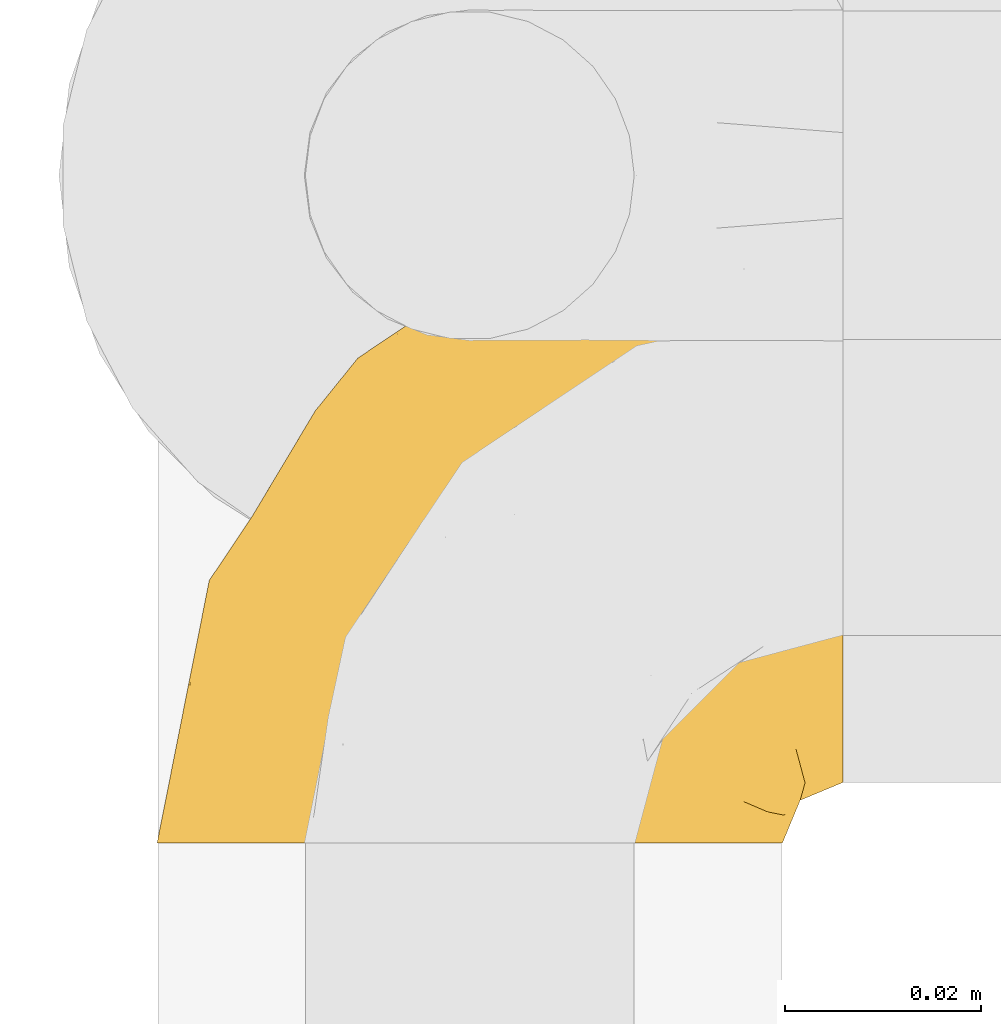
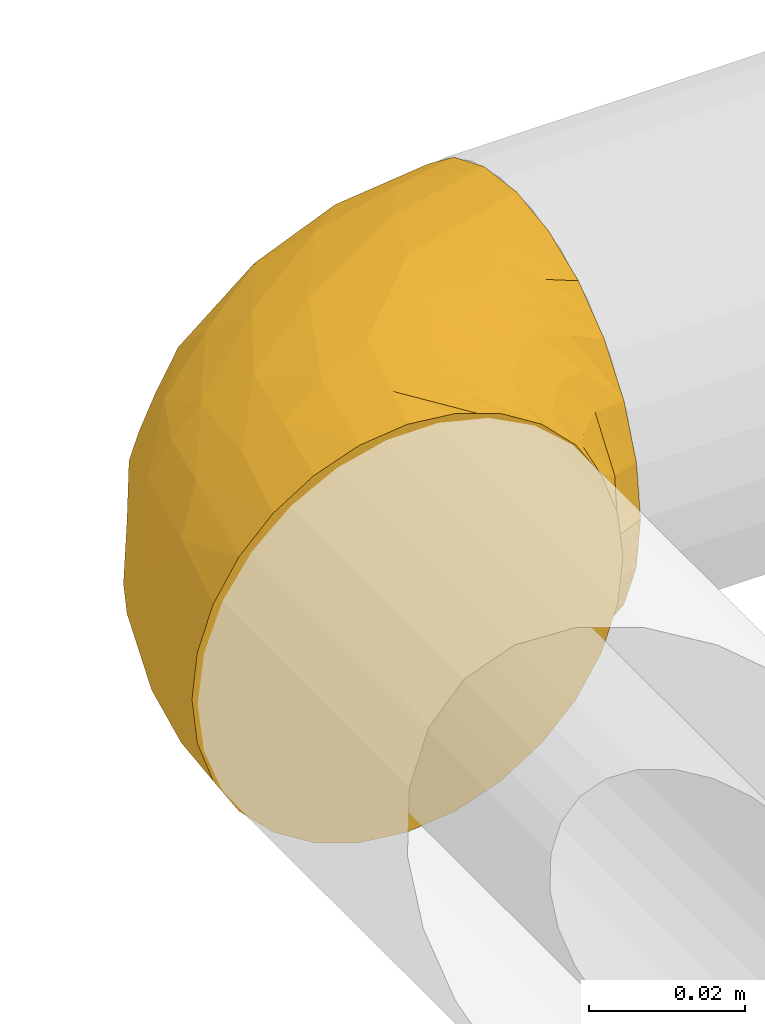
# One storey, part 26 of 39: 1 covering.
"""IFC2X3 building model written with IfcOpenShell, lengths in millimetres."""

from ifc_helpers import new_model, entity, si_unit, converted_unit, derived_unit, direction, frame, origin, place, context, subcontext, project, spatial, faceted_brep, element, save


model = new_model("IFC2X3")

# Units and contexts
model_context = context("Model", 3, precision=0.01, world=origin(), true_north=direction((6.12303176911189e-17, 1.0)))
body_context = subcontext(model_context, "Body", "Model", "MODEL_VIEW")
ifc_project = project(units=[si_unit("LENGTHUNIT", "METRE", prefix="MILLI"), si_unit("AREAUNIT", "SQUARE_METRE"), si_unit("VOLUMEUNIT", "CUBIC_METRE"), converted_unit("PLANEANGLEUNIT", "DEGREE", entity("IfcRatioMeasure", 0.0174532925199433), si_unit("PLANEANGLEUNIT", "RADIAN"), dimensions=[0, 0, 0, 0, 0, 0, 0]), si_unit("MASSUNIT", "GRAM", prefix="KILO"), derived_unit("MASSDENSITYUNIT", [(si_unit("MASSUNIT", "GRAM", prefix="KILO"), 1), (si_unit("LENGTHUNIT", "METRE"), -3)]), derived_unit("MOMENTOFINERTIAUNIT", [(si_unit("LENGTHUNIT", "METRE"), 4)]), si_unit("TIMEUNIT", "SECOND"), si_unit("FREQUENCYUNIT", "HERTZ"), si_unit("THERMODYNAMICTEMPERATUREUNIT", "DEGREE_CELSIUS"), derived_unit("THERMALTRANSMITTANCEUNIT", [(si_unit("MASSUNIT", "GRAM", prefix="KILO"), 1), (si_unit("THERMODYNAMICTEMPERATUREUNIT", "KELVIN"), -1), (si_unit("TIMEUNIT", "SECOND"), -3)]), derived_unit("VOLUMETRICFLOWRATEUNIT", [(si_unit("LENGTHUNIT", "METRE"), 3), (si_unit("TIMEUNIT", "SECOND"), -1)]), derived_unit("MASSFLOWRATEUNIT", [(si_unit("MASSUNIT", "GRAM", prefix="KILO"), 1), (si_unit("TIMEUNIT", "SECOND"), -1)]), derived_unit("ROTATIONALFREQUENCYUNIT", [(si_unit("TIMEUNIT", "SECOND"), -1)]), si_unit("ELECTRICCURRENTUNIT", "AMPERE"), si_unit("ELECTRICVOLTAGEUNIT", "VOLT"), si_unit("POWERUNIT", "WATT"), si_unit("FORCEUNIT", "NEWTON", prefix="KILO"), si_unit("ILLUMINANCEUNIT", "LUX"), si_unit("LUMINOUSFLUXUNIT", "LUMEN"), si_unit("LUMINOUSINTENSITYUNIT", "CANDELA"), derived_unit("USERDEFINED", [(si_unit("MASSUNIT", "GRAM", prefix="KILO"), -1), (si_unit("LENGTHUNIT", "METRE"), -2), (si_unit("TIMEUNIT", "SECOND"), 3), (si_unit("LUMINOUSFLUXUNIT", "LUMEN"), 1)]), derived_unit("LINEARVELOCITYUNIT", [(si_unit("LENGTHUNIT", "METRE"), 1), (si_unit("TIMEUNIT", "SECOND"), -1)]), si_unit("PRESSUREUNIT", "PASCAL"), derived_unit("USERDEFINED", [(si_unit("LENGTHUNIT", "METRE"), -2), (si_unit("MASSUNIT", "GRAM", prefix="KILO"), 1), (si_unit("TIMEUNIT", "SECOND"), -2)]), derived_unit("LINEARFORCEUNIT", [(si_unit("MASSUNIT", "GRAM", prefix="KILO"), 1), (si_unit("LENGTHUNIT", "METRE"), 1), (si_unit("TIMEUNIT", "SECOND"), -2), (si_unit("LENGTHUNIT", "METRE"), -1)]), derived_unit("PLANARFORCEUNIT", [(si_unit("MASSUNIT", "GRAM", prefix="KILO"), 1), (si_unit("LENGTHUNIT", "METRE"), 1), (si_unit("TIMEUNIT", "SECOND"), -2), (si_unit("LENGTHUNIT", "METRE"), -2)])], contexts=[model_context])

# Site, building, storey
site_placement = place(None, origin())
site = spatial("IfcSite", under=ifc_project, at=site_placement, CompositionType="ELEMENT")
building_placement = place(site_placement, origin())
building = spatial("IfcBuilding", under=site, at=building_placement, CompositionType="ELEMENT")
storey_placement = place(building_placement, frame((0.0, 0.0, 24000.0)))
storey = spatial("IfcBuildingStorey", under=building, at=storey_placement, Name="07", CompositionType="ELEMENT", Elevation=24000.0)

# Covering
covering_placement = place(storey_placement, frame((71731.57, 5227.76, 3046.55)))
element("IfcCovering", 1, at=covering_placement, inside=storey, Name=":ADSK_", ObjectType=":ADSK_", PredefinedType="INSULATION", context=body_context, shape_type="Brep", body=[
    faceted_brep([(2.39, 1.6, 40.53), (1.6, 1.6, 33.45), (2.39, 1.6, 26.35), (4.75, 1.6, 19.62), (8.55, 1.6, 13.58), (13.59, 1.6, 8.54), (19.63, 1.6, 4.75), (26.36, 1.6, 2.39), (33.45, 1.6, 1.6), (37.35, 1.6, 2.04), (40.54, 1.6, 2.39), (43.9, 1.6, 3.57), (47.27, 1.6, 4.75), (53.31, 1.6, 8.55), (58.35, 1.6, 13.59), (62.14, 1.6, 19.63), (64.5, 1.6, 26.36), (65.3, 1.6, 33.45), (64.5, 1.6, 40.54), (62.14, 1.6, 47.27), (58.34, 1.6, 53.31), (53.3, 1.6, 58.35), (47.26, 1.6, 62.14), (43.89, 1.6, 63.32), (40.53, 1.6, 64.5), (37.35, 1.6, 64.86), (35.4, 1.6, 65.08), (33.45, 1.6, 65.3), (26.35, 1.6, 64.5), (19.62, 1.6, 62.14), (13.58, 1.6, 58.34), (8.54, 1.6, 53.3), (4.75, 1.6, 47.26), (71.45, 23.67, 5.86), (71.45, 27.51, 4.27), (71.45, 31.35, 2.68), (71.45, 35.67, 2.11), (71.45, 37.63, 1.85), (71.45, 39.6, 1.6), (71.45, 47.84, 2.68), (71.45, 55.52, 5.86), (71.45, 62.12, 10.92), (71.45, 67.18, 17.52), (71.45, 70.36, 25.2), (71.45, 71.45, 33.45), (71.45, 70.36, 41.69), (71.45, 67.18, 49.37), (71.45, 62.12, 55.97), (71.45, 55.52, 61.03), (71.45, 47.84, 64.21), (71.45, 39.6, 65.3), (71.45, 35.67, 64.78), (71.45, 31.35, 64.21), (71.45, 27.51, 62.62), (71.45, 23.67, 61.03), (71.45, 20.37, 58.5), (71.45, 17.07, 55.97), (71.45, 12.01, 49.37), (71.45, 8.83, 41.69), (71.45, 7.75, 33.45), (71.45, 8.83, 25.2), (71.45, 12.01, 17.52), (71.45, 17.07, 10.92), (71.45, 20.37, 8.39), (37.48, 33.94, 64.03), (38.54, 20.6, 65.3), (42.01, 24.07, 65.3), (45.49, 27.55, 65.3), (48.97, 31.03, 65.3), (52.45, 34.5, 65.3), (58.08, 68.79, 33.45), (40.84, 53.62, 56.13), (47.91, 50.17, 61.0), (55.67, 58.62, 57.25), (55.18, 67.51, 44.44), (45.13, 61.03, 50.33), (59.19, 64.5, 51.72), (11.67, 17.98, 54.4), (38.17, 61.71, 41.87), (28.82, 52.25, 48.25), (29.48, 16.72, 64.6), (32.11, 39.09, 60.78), (24.68, 25.86, 61.71), (55.82, 44.07, 64.46), (28.37, 44.36, 55.78), (9.18, 31.35, 40.71), (4.95, 17.72, 42.87), (11.17, 29.45, 47.87), (60.89, 52.37, 62.12), (55.35, 35.28, 65.3), (58.25, 36.06, 65.3), (61.15, 36.84, 65.3), (64.05, 37.61, 65.3), (65.9, 38.11, 65.3), (67.75, 38.61, 65.3), (16.27, 14.07, 59.32), (6.97, 13.65, 49.35), (4.25, 14.96, 33.45), (21.84, 13.32, 62.53), (33.94, 3.44, 65.3), (34.44, 5.29, 65.3), (35.43, 8.99, 65.3), (36.2, 11.89, 65.3), (36.98, 14.79, 65.3), (37.76, 17.69, 65.3), (18.84, 29.19, 57.03), (14.39, 28.91, 52.84), (51.68, 68.17, 38.52), (6.91, 28.33, 33.45), (26.05, 53.45, 41.09), (33.38, 58.56, 33.45), (22.05, 50.99, 33.45), (17.7, 43.14, 44.35), (19.21, 39.23, 51.29), (44.71, 66.13, 33.45), (17.7, 45.6, 38.44), (14.48, 39.66, 33.45), (66.98, 18.04, 57.42), (65.01, 22.76, 61.06), (61.98, 21.95, 61.24), (64.85, 32.18, 64.58), (62.15, 29.08, 64.0), (48.67, 20.77, 64.21), (63.81, 4.75, 44.85), (50.71, 11.03, 61.42), (48.45, 6.78, 61.84), (52.85, 5.68, 59.03), (67.6, 7.71, 41.64), (65.48, 4.42, 38.8), (67.1, 5.94, 33.45), (66.68, 14.52, 54.12), (43.2, 11.63, 64.27), (44.92, 6.6, 63.33), (58.1, 7.33, 54.97), (61.92, 12.48, 54.91), (63.17, 7.99, 49.44), (66.68, 11.14, 49.79), (56.7, 14.07, 59.23), (50.86, 15.37, 62.42), (54.42, 10.81, 59.27), (40.7, 7.89, 64.6), (57.76, 26.18, 63.73), (61.34, 5.8, 50.25), (59.9, 9.94, 54.66), (58.0, 22.23, 62.35), (62.43, 18.39, 59.05), (45.83, 17.71, 64.34), (58.99, 16.87, 59.52), (45.9, 13.24, 63.71), (67.3, 24.95, 61.92), (53.12, 26.59, 64.52), (49.43, 26.16, 64.9), (53.9, 22.11, 63.33), (52.92, 17.43, 62.23), (63.81, 4.75, 22.04), (61.35, 5.8, 16.65), (63.17, 7.99, 17.46), (56.72, 14.07, 7.66), (59.87, 10.06, 12.13), (54.39, 11.54, 7.35), (67.59, 7.71, 25.25), (40.71, 7.89, 2.29), (35.43, 8.99, 1.6), (36.2, 11.89, 1.6), (36.98, 14.79, 1.6), (65.48, 4.42, 28.1), (58.19, 22.42, 4.51), (55.78, 27.95, 2.45), (62.46, 22.22, 5.62), (69.6, 39.1, 1.6), (61.15, 36.84, 1.6), (64.05, 37.61, 1.6), (67.75, 38.61, 1.6), (67.39, 21.49, 6.96), (66.16, 26.52, 4.16), (58.11, 18.09, 6.38), (62.44, 18.39, 7.84), (61.95, 13.88, 10.87), (66.68, 11.14, 17.1), (64.85, 32.18, 2.31), (52.45, 34.5, 1.6), (48.97, 31.03, 1.6), (43.18, 11.65, 2.62), (52.88, 5.67, 7.88), (48.46, 6.81, 5.05), (34.44, 5.29, 1.6), (34.93, 7.14, 1.6), (58.11, 7.34, 11.92), (58.25, 36.06, 1.6), (60.72, 31.38, 2.23), (49.13, 19.83, 2.95), (45.49, 27.55, 1.6), (53.71, 22.94, 3.29), (44.93, 6.6, 3.56), (67.04, 17.93, 9.57), (66.6, 14.52, 12.74), (44.91, 17.45, 2.39), (50.72, 11.03, 5.47), (37.76, 17.69, 1.6), (38.54, 20.6, 1.6), (46.39, 12.33, 3.46), (57.7, 30.27, 2.2), (55.35, 35.28, 1.6), (62.73, 25.9, 4.02), (42.01, 24.07, 1.6), (55.67, 58.62, 9.64), (21.85, 13.32, 4.35), (29.49, 16.72, 2.29), (55.82, 44.07, 2.43), (38.17, 61.71, 25.02), (55.18, 67.51, 22.45), (45.12, 61.03, 16.56), (47.92, 50.18, 5.89), (37.47, 33.92, 2.86), (32.11, 39.08, 6.1), (40.85, 53.62, 10.76), (51.68, 68.17, 28.37), (60.89, 52.37, 4.77), (59.19, 64.5, 15.17), (24.69, 25.86, 5.18), (16.28, 14.07, 7.56), (18.85, 29.18, 9.85), (11.19, 29.46, 19.01), (4.95, 17.73, 24.01), (9.19, 31.37, 26.18), (11.68, 17.99, 12.48), (26.05, 53.45, 25.8), (19.23, 39.25, 15.6), (14.4, 28.92, 14.04), (6.97, 13.65, 17.53), (28.8, 52.23, 18.64), (17.7, 43.13, 22.54), (28.37, 44.36, 11.1), (17.7, 45.6, 28.45)], [[[0, 1, 2, 3, 4, 5, 6, 7, 8, 9, 10, 11, 12, 13, 14, 15, 16, 17, 18, 19, 20, 21, 22, 23, 24, 25, 26, 27, 28, 29, 30, 31, 32]], [[33, 34, 35, 36, 37, 38, 39, 40, 41, 42, 43, 44, 45, 46, 47, 48, 49, 50, 51, 52, 53, 54, 55, 56, 57, 58, 59, 60, 61, 62, 63]], [[64, 65, 66, 67, 68, 69]], [[45, 44, 70]], [[71, 72, 73]], [[74, 75, 76]], [[77, 31, 30]], [[75, 78, 79]], [[27, 80, 28]], [[74, 46, 45]], [[64, 81, 82]], [[46, 76, 47]], [[83, 50, 49]], [[48, 47, 73]], [[71, 79, 84]], [[85, 86, 87]], [[49, 48, 88]], [[83, 69, 89, 90, 91, 92, 93, 94, 50]], [[95, 77, 30]], [[75, 74, 78]], [[87, 86, 96]], [[96, 86, 32]], [[96, 32, 31]], [[0, 86, 97]], [[83, 64, 69]], [[98, 80, 82]], [[73, 72, 88]], [[64, 80, 65]], [[1, 0, 97]], [[80, 27, 99, 100, 101, 102, 103, 104, 65]], [[77, 105, 106]], [[64, 82, 80]], [[70, 107, 45]], [[77, 95, 105]], [[82, 95, 98]], [[95, 30, 29]], [[74, 107, 78]], [[86, 0, 32]], [[72, 71, 81]], [[85, 108, 86]], [[76, 73, 47]], [[71, 84, 81]], [[109, 110, 111]], [[87, 112, 85]], [[79, 109, 112]], [[79, 112, 113]], [[88, 83, 49]], [[64, 83, 72]], [[31, 77, 96]], [[87, 96, 77]], [[98, 95, 29]], [[105, 95, 82]], [[81, 105, 82]], [[105, 84, 113]], [[29, 28, 98]], [[114, 107, 70]], [[80, 98, 28]], [[73, 75, 71]], [[79, 71, 75]], [[74, 76, 46]], [[73, 76, 75]], [[78, 107, 114]], [[45, 107, 74]], [[87, 113, 112]], [[115, 85, 112]], [[109, 79, 78]], [[113, 87, 106]], [[116, 115, 111]], [[116, 108, 85]], [[79, 113, 84]], [[109, 78, 110]], [[115, 109, 111]], [[85, 115, 116]], [[109, 115, 112]], [[72, 81, 64]], [[105, 81, 84]], [[73, 88, 48]], [[83, 88, 72]], [[86, 108, 97]], [[78, 114, 110]], [[113, 106, 105]], [[87, 77, 106]], [[117, 118, 119]], [[52, 120, 54, 53]], [[91, 120, 52]], [[91, 90, 120]], [[90, 121, 120]], [[122, 67, 66]], [[18, 123, 19]], [[124, 125, 126]], [[127, 59, 58]], [[128, 129, 127]], [[130, 57, 117]], [[131, 132, 125]], [[19, 133, 20]], [[128, 18, 17]], [[134, 135, 136]], [[137, 138, 139]], [[131, 103, 140]], [[22, 140, 23]], [[131, 65, 104, 103]], [[99, 27, 26, 25, 24, 101, 100]], [[141, 118, 121]], [[19, 123, 142]], [[52, 51, 50, 94, 93, 92, 91]], [[129, 128, 17]], [[117, 56, 118]], [[135, 134, 143]], [[139, 126, 133]], [[119, 144, 145]], [[127, 135, 123]], [[136, 58, 57]], [[101, 24, 23]], [[124, 138, 146]], [[140, 101, 23]], [[145, 147, 134]], [[140, 132, 131]], [[140, 103, 102, 101]], [[140, 22, 132]], [[146, 148, 124]], [[121, 69, 141]], [[55, 149, 118]], [[150, 151, 152]], [[147, 137, 134]], [[144, 150, 152]], [[152, 151, 122]], [[138, 122, 146]], [[59, 127, 129]], [[123, 18, 128]], [[58, 136, 127]], [[135, 127, 136]], [[121, 90, 89, 69]], [[120, 121, 149]], [[122, 66, 146]], [[153, 122, 138]], [[141, 69, 68]], [[127, 123, 128]], [[123, 135, 142]], [[143, 142, 135]], [[19, 142, 133]], [[66, 65, 146]], [[148, 65, 131]], [[22, 21, 132]], [[125, 132, 21]], [[126, 125, 21]], [[148, 125, 124]], [[21, 20, 126]], [[133, 126, 20]], [[139, 138, 124]], [[153, 138, 137]], [[126, 139, 124]], [[139, 133, 143]], [[147, 153, 137]], [[152, 122, 153]], [[134, 136, 130]], [[137, 139, 143]], [[144, 147, 145]], [[153, 147, 152]], [[65, 148, 146]], [[125, 148, 131]], [[141, 144, 119]], [[55, 54, 149]], [[137, 143, 134]], [[142, 143, 133]], [[130, 117, 145]], [[57, 56, 117]], [[134, 130, 145]], [[57, 130, 136]], [[150, 144, 141]], [[147, 144, 152]], [[141, 68, 150]], [[151, 68, 67]], [[117, 119, 145]], [[141, 119, 118]], [[68, 151, 150]], [[122, 151, 67]], [[118, 56, 55]], [[120, 149, 54]], [[118, 149, 121]], [[154, 155, 156]], [[157, 158, 159]], [[129, 160, 59]], [[161, 162, 163, 164]], [[165, 160, 129]], [[166, 167, 168]], [[169, 38, 37, 36, 35, 170, 171, 172]], [[63, 173, 174]], [[175, 176, 177]], [[60, 178, 61]], [[179, 35, 34, 33]], [[160, 60, 59]], [[180, 167, 181]], [[129, 17, 165]], [[182, 161, 164]], [[183, 13, 184]], [[9, 8, 185, 186, 162, 10]], [[187, 155, 15]], [[188, 179, 189]], [[187, 15, 14]], [[190, 191, 192]], [[182, 193, 161]], [[194, 176, 168]], [[176, 195, 177]], [[196, 190, 197]], [[11, 10, 162]], [[11, 161, 12]], [[187, 14, 183]], [[12, 161, 193]], [[156, 158, 177]], [[165, 17, 16]], [[194, 195, 176]], [[187, 159, 158]], [[179, 174, 189]], [[182, 164, 198, 199]], [[200, 199, 196]], [[193, 184, 13]], [[194, 168, 173]], [[201, 202, 189]], [[16, 154, 165]], [[160, 156, 178]], [[160, 165, 154]], [[178, 60, 160]], [[170, 35, 179]], [[188, 170, 179]], [[189, 174, 203]], [[174, 179, 33]], [[201, 189, 203]], [[181, 192, 191]], [[167, 180, 201]], [[192, 175, 190]], [[159, 190, 157]], [[15, 154, 16]], [[204, 196, 199]], [[204, 191, 190]], [[160, 154, 156]], [[15, 155, 154]], [[158, 155, 187]], [[203, 173, 168]], [[192, 181, 167]], [[190, 196, 204]], [[200, 196, 197]], [[184, 193, 182]], [[13, 12, 193]], [[200, 184, 182]], [[184, 200, 183]], [[187, 183, 197]], [[14, 13, 183]], [[162, 161, 11]], [[63, 62, 173]], [[174, 33, 63]], [[173, 62, 194]], [[174, 173, 203]], [[62, 61, 194]], [[195, 61, 178]], [[61, 195, 194]], [[177, 195, 178]], [[156, 177, 178]], [[175, 192, 166]], [[166, 168, 176]], [[167, 203, 168]], [[175, 166, 176]], [[167, 166, 192]], [[177, 157, 175]], [[190, 175, 157]], [[187, 197, 159]], [[190, 159, 197]], [[177, 158, 157]], [[155, 158, 156]], [[167, 201, 203]], [[200, 197, 183]], [[202, 201, 180]], [[202, 188, 189]], [[199, 200, 182]], [[41, 40, 205]], [[206, 207, 7]], [[208, 38, 169, 172, 171, 170, 188, 202, 180]], [[209, 210, 211]], [[212, 213, 214]], [[212, 215, 205]], [[43, 210, 216]], [[217, 40, 39]], [[216, 114, 70]], [[208, 213, 212]], [[205, 40, 217]], [[218, 42, 41]], [[216, 209, 114]], [[42, 218, 210]], [[214, 213, 219]], [[219, 220, 221]], [[199, 207, 213]], [[213, 207, 219]], [[8, 7, 207]], [[222, 223, 224]], [[4, 225, 5]], [[2, 97, 223]], [[110, 226, 111]], [[225, 220, 5]], [[227, 221, 228]], [[223, 229, 3]], [[2, 223, 3]], [[230, 231, 226]], [[224, 223, 108]], [[42, 210, 43]], [[230, 209, 211]], [[222, 225, 229]], [[38, 208, 39]], [[3, 229, 4]], [[213, 180, 181, 191, 204, 199]], [[220, 206, 6]], [[5, 220, 6]], [[207, 199, 198, 164, 163, 162, 186, 185, 8]], [[212, 214, 215]], [[218, 205, 211]], [[211, 215, 230]], [[226, 110, 209]], [[222, 231, 227]], [[222, 224, 231]], [[213, 208, 180]], [[217, 208, 212]], [[222, 229, 223]], [[225, 4, 229]], [[221, 220, 225]], [[206, 220, 219]], [[228, 221, 225]], [[214, 221, 232]], [[207, 206, 219]], [[44, 43, 70]], [[7, 6, 206]], [[230, 215, 232]], [[211, 205, 215]], [[205, 218, 41]], [[210, 218, 211]], [[43, 216, 70]], [[209, 216, 210]], [[233, 116, 111]], [[230, 232, 227]], [[224, 116, 233]], [[230, 226, 209]], [[224, 108, 116]], [[230, 227, 231]], [[221, 227, 232]], [[233, 226, 231]], [[225, 222, 228]], [[226, 233, 111]], [[224, 233, 231]], [[221, 214, 219]], [[214, 232, 215]], [[208, 217, 39]], [[205, 217, 212]], [[97, 2, 1]], [[97, 108, 223]], [[110, 114, 209]], [[227, 228, 222]]]),
])

save(model, "model.ifc")
